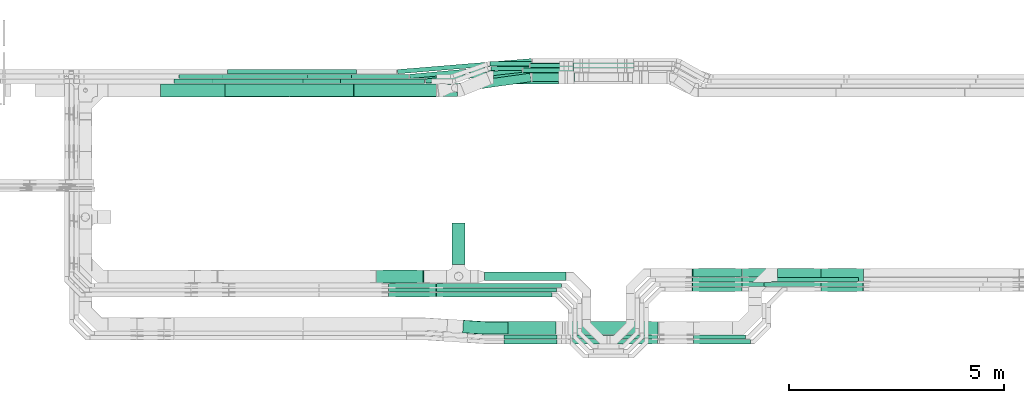
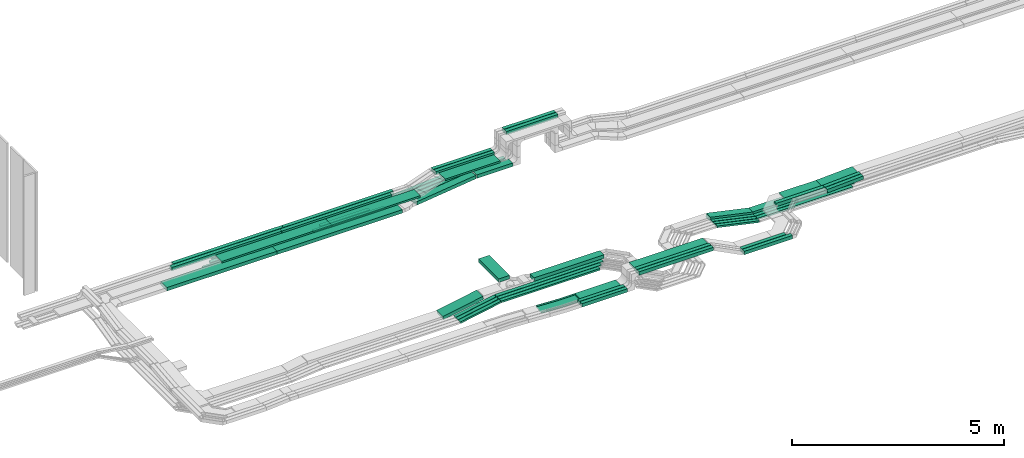
# One storey, part 2 of 33: 54 flow segments, 1 flow fitting.
"""IFC2X3 building model written with IfcOpenShell, lengths in millimetres."""

from ifc_helpers import new_model, entity, si_unit, converted_unit, derived_unit, direction, frame, frame_2d, origin, origin_2d_with_axis, place, context, subcontext, project, spatial, rectangle, extrude, faceted_brep, source, transform, mapped, material, type_object, type_shapes, element, save


model = new_model("IFC2X3")

# Units and contexts
model_context = context("Model", 3, precision=0.01, world=origin(), true_north=direction((6.12303176911189e-17, 1.0)))
body_context = subcontext(model_context, "Body", "Model", "MODEL_VIEW")
ifc_project = project(units=[si_unit("LENGTHUNIT", "METRE", prefix="MILLI"), si_unit("AREAUNIT", "SQUARE_METRE"), si_unit("VOLUMEUNIT", "CUBIC_METRE"), converted_unit("PLANEANGLEUNIT", "DEGREE", entity("IfcRatioMeasure", 0.0174532925199433), si_unit("PLANEANGLEUNIT", "RADIAN"), dimensions=[0, 0, 0, 0, 0, 0, 0]), si_unit("MASSUNIT", "GRAM", prefix="KILO"), derived_unit("MASSDENSITYUNIT", [(si_unit("MASSUNIT", "GRAM", prefix="KILO"), 1), (si_unit("LENGTHUNIT", "METRE"), -3)]), derived_unit("MOMENTOFINERTIAUNIT", [(si_unit("LENGTHUNIT", "METRE"), 4)]), si_unit("TIMEUNIT", "SECOND"), si_unit("FREQUENCYUNIT", "HERTZ"), si_unit("THERMODYNAMICTEMPERATUREUNIT", "DEGREE_CELSIUS"), derived_unit("THERMALTRANSMITTANCEUNIT", [(si_unit("MASSUNIT", "GRAM", prefix="KILO"), 1), (si_unit("THERMODYNAMICTEMPERATUREUNIT", "KELVIN"), -1), (si_unit("TIMEUNIT", "SECOND"), -3)]), derived_unit("VOLUMETRICFLOWRATEUNIT", [(si_unit("LENGTHUNIT", "METRE"), 3), (si_unit("TIMEUNIT", "SECOND"), -1)]), derived_unit("MASSFLOWRATEUNIT", [(si_unit("MASSUNIT", "GRAM", prefix="KILO"), 1), (si_unit("TIMEUNIT", "SECOND"), -1)]), derived_unit("ROTATIONALFREQUENCYUNIT", [(si_unit("TIMEUNIT", "SECOND"), -1)]), si_unit("ELECTRICCURRENTUNIT", "AMPERE"), si_unit("ELECTRICVOLTAGEUNIT", "VOLT"), si_unit("POWERUNIT", "WATT"), si_unit("FORCEUNIT", "NEWTON", prefix="KILO"), si_unit("ILLUMINANCEUNIT", "LUX"), si_unit("LUMINOUSFLUXUNIT", "LUMEN"), si_unit("LUMINOUSINTENSITYUNIT", "CANDELA"), derived_unit("USERDEFINED", [(si_unit("MASSUNIT", "GRAM", prefix="KILO"), -1), (si_unit("LENGTHUNIT", "METRE"), -2), (si_unit("TIMEUNIT", "SECOND"), 3), (si_unit("LUMINOUSFLUXUNIT", "LUMEN"), 1)]), derived_unit("LINEARVELOCITYUNIT", [(si_unit("LENGTHUNIT", "METRE"), 1), (si_unit("TIMEUNIT", "SECOND"), -1)]), si_unit("PRESSUREUNIT", "PASCAL"), derived_unit("USERDEFINED", [(si_unit("LENGTHUNIT", "METRE"), -2), (si_unit("MASSUNIT", "GRAM", prefix="KILO"), 1), (si_unit("TIMEUNIT", "SECOND"), -2)]), derived_unit("LINEARFORCEUNIT", [(si_unit("MASSUNIT", "GRAM", prefix="KILO"), 1), (si_unit("LENGTHUNIT", "METRE"), 1), (si_unit("TIMEUNIT", "SECOND"), -2), (si_unit("LENGTHUNIT", "METRE"), -1)]), derived_unit("PLANARFORCEUNIT", [(si_unit("MASSUNIT", "GRAM", prefix="KILO"), 1), (si_unit("LENGTHUNIT", "METRE"), 1), (si_unit("TIMEUNIT", "SECOND"), -2), (si_unit("LENGTHUNIT", "METRE"), -2)])], contexts=[model_context])

# Site, building, storey
site_placement = place(None, frame((0.0, -0.00077364408347762, 0.0)))
site = spatial("IfcSite", under=ifc_project, at=site_placement, CompositionType="ELEMENT")
building_placement = place(site_placement, origin())
building = spatial("IfcBuilding", under=site, at=building_placement, CompositionType="ELEMENT")
storey_placement = place(building_placement, frame((0.0, 0.0, 8100.0)))
storey = spatial("IfcBuildingStorey", under=building, at=storey_placement, CompositionType="ELEMENT", Elevation=8100.0)

# Flow segments
cable_carrier_segment_type = type_object("IfcCableCarrierSegmentType", PredefinedType="CABLETRAYSEGMENT")
flow_segment_1_placement = place(storey_placement, frame((26941.0061453203, 10274.9985534668, 2800.0)))
element("IfcFlowSegment", 1, at=flow_segment_1_placement, inside=storey, type_object=cable_carrier_segment_type, context=body_context, shape_type="SweptSolid", body=[
    extrude(rectangle(XDim=962.025403932725, YDim=300.000000000001, at=frame_2d((-1.08002495835535e-12, 0.0), x_axis=(1.0, 0.0))), frame((150.0, 481.012701966363, 0.0), z_axis=(0.0, 0.0, 1.0), x_axis=(0.0, 1.0, 0.0)), (0.0, 0.0, 1.0), 99.9999999999968),
])
flow_segment_2_placement = place(storey_placement, frame((23148.437324407, 14174.4992263561, 2565.0)))
element("IfcFlowSegment", 2, at=flow_segment_2_placement, inside=storey, type_object=cable_carrier_segment_type, context=body_context, shape_type="SweptSolid", body=[
    extrude(rectangle(XDim=3423.65642864429, YDim=300.000000000001, at=frame_2d((-2.1600499167107e-12, -1.08002495835535e-12), x_axis=(1.0, 0.0))), frame((1711.82821432215, 150.0, 0.0), z_axis=(0.0, 0.0, 1.0), x_axis=(-1.0, 0.0, 0.0)), (0.0, 0.0, 1.0), 99.9999999999989),
])
flow_segment_3_placement = place(storey_placement, frame((28591.6886277084, 14750.0572451365, 2565.34290576127)))
element("IfcFlowSegment", 3, at=flow_segment_3_placement, inside=storey, type_object=cable_carrier_segment_type, context=body_context, shape_type="SweptSolid", body=[
    extrude(rectangle(XDim=1171.51047122399, YDim=99.9999999999989, at=origin_2d_with_axis()), frame((585.755235611997, 50.0, 0.0), z_axis=(0.0, 0.0, 1.0), x_axis=(-1.0, 0.0, 0.0)), (0.0, 0.0, 1.0), 50.0000000000016),
])
flow_segment_4_placement = place(storey_placement, frame((28756.9717562962, 14860.0572451365, 2570.0)))
element("IfcFlowSegment", 4, at=flow_segment_4_placement, inside=storey, type_object=cable_carrier_segment_type, context=body_context, shape_type="SweptSolid", body=[
    extrude(rectangle(XDim=1006.22734263624, YDim=99.9999999999989, at=frame_2d((2.1600499167107e-12, 0.0), x_axis=(1.0, 0.0))), frame((503.11367131812, 50.0, 0.0), z_axis=(0.0, 0.0, 1.0), x_axis=(-1.0, 0.0, 0.0)), (0.0, 0.0, 1.0), 50.0000000000016),
])
flow_segment_5_placement = place(storey_placement, frame((27693.0061453203, 9894.99855346675, 2800.0)))
element("IfcFlowSegment", 5, at=flow_segment_5_placement, inside=storey, type_object=cable_carrier_segment_type, context=body_context, shape_type="SweptSolid", body=[
    extrude(rectangle(XDim=1902.46225527867, YDim=199.999999999998, at=frame_2d((-4.37694325228222e-12, 1.08002495835535e-12), x_axis=(1.0, 0.0))), frame((951.231127639338, 100.0, 0.0)), (0.0, 0.0, 1.0), 100.000000000001),
])
flow_segment_6_placement = place(storey_placement, frame((29758.1990989324, 14900.0572451365, 3324.99867972438)))
element("IfcFlowSegment", 6, at=flow_segment_6_placement, inside=storey, type_object=cable_carrier_segment_type, context=body_context, shape_type="SweptSolid", body=[
    extrude(rectangle(XDim=1413.21398337131, YDim=99.9999999999989, at=frame_2d((-2.1600499167107e-12, 0.0), x_axis=(1.0, 0.0))), frame((706.606991685651, 50.0, 0.0)), (0.0, 0.0, 1.0), 99.9999999999989),
])
flow_segment_7_placement = place(storey_placement, frame((29758.1990989324, 14790.0572451365, 3324.99867972438)))
element("IfcFlowSegment", 7, at=flow_segment_7_placement, inside=storey, type_object=cable_carrier_segment_type, context=body_context, shape_type="SweptSolid", body=[
    extrude(rectangle(XDim=1413.2139833713, YDim=99.9999999999989, at=origin_2d_with_axis()), frame((706.606991685651, 50.0, 0.0)), (0.0, 0.0, 1.0), 99.9999999999989),
])
flow_segment_8_placement = place(storey_placement, frame((27909.7567007501, 14480.0572451366, 2840.01712441882)))
element("IfcFlowSegment", 8, at=flow_segment_8_placement, inside=storey, type_object=cable_carrier_segment_type, context=body_context, shape_type="SweptSolid", body=[
    extrude(rectangle(XDim=1503.44239818237, YDim=300.000000000001, at=origin_2d_with_axis()), frame((751.721199091186, 150.0, 0.0), z_axis=(0.0, 0.0, 1.0), x_axis=(-1.0, 0.0, 0.0)), (0.0, 0.0, 1.0), 50.0000000000016),
])
flow_segment_9_placement = place(storey_placement, frame((27841.258991739, 14790.0572451365, 2840.0)))
element("IfcFlowSegment", 9, at=flow_segment_9_placement, inside=storey, type_object=cable_carrier_segment_type, context=body_context, shape_type="SweptSolid", body=[
    extrude(rectangle(XDim=1596.94010719343, YDim=99.9999999999989, at=frame_2d((-2.1600499167107e-12, 0.0), x_axis=(1.0, 0.0))), frame((798.470053596716, 50.0, 0.0), z_axis=(0.0, 0.0, 1.0), x_axis=(-1.0, 0.0, 0.0)), (0.0, 0.0, 1.0), 99.9999999999989),
])
flow_segment_10_placement = place(storey_placement, frame((27825.5058887975, 14900.0572451365, 2840.0)))
element("IfcFlowSegment", 10, at=flow_segment_10_placement, inside=storey, type_object=cable_carrier_segment_type, context=body_context, shape_type="SweptSolid", body=[
    extrude(rectangle(XDim=1612.69321013494, YDim=99.9999999999989, at=frame_2d((2.1600499167107e-12, -2.16715534406831e-12), x_axis=(1.0, 0.0))), frame((806.346605067471, 50.0, 0.0), z_axis=(0.0, 0.0, 1.0), x_axis=(-1.0, 0.0, 0.0)), (0.0, 0.0, 1.0), 99.9999999999989),
])
flow_segment_11_placement = place(storey_placement, frame((28805.1753458545, 14532.2782357463, 2565.0)))
element("IfcFlowSegment", 11, at=flow_segment_11_placement, inside=storey, type_object=cable_carrier_segment_type, context=body_context, shape_type="SweptSolid", body=[
    extrude(rectangle(XDim=983.02375307789, YDim=199.999999999998, at=frame_2d((0.0, 1.08002495835535e-12), x_axis=(1.0, 0.0))), frame((491.511876538945, 100.0, 0.0), z_axis=(0.0, 0.0, 1.0), x_axis=(-1.0, 0.0, 0.0)), (0.0, 0.0, 1.0), 99.9999999999989),
])
flow_segment_12_placement = place(storey_placement, frame((26317.4081518589, 14493.9896855874, 2565.34290576127)))
element("IfcFlowSegment", 12, at=flow_segment_12_placement, inside=storey, type_object=cable_carrier_segment_type, context=body_context, shape_type="SweptSolid", body=[
    extrude(rectangle(XDim=2258.501959598, YDim=99.9999999999987, at=frame_2d((2.27373675443232e-12, 8.20676859802916e-13), x_axis=(1.0, 0.0))), frame((1127.67558113492, 177.178054854003, 0.0), z_axis=(0.0, 0.0, 1.0), x_axis=(-0.993605819509294, -0.112904718401246, 0.0)), (0.0, 0.0, 1.0), 50.0000000000016),
])
flow_segment_13_placement = place(storey_placement, frame((25948.9674028795, 14603.4200619656, 2570.0)))
element("IfcFlowSegment", 13, at=flow_segment_13_placement, inside=storey, type_object=cable_carrier_segment_type, context=body_context, shape_type="SweptSolid", body=[
    extrude(rectangle(XDim=2794.85823056188, YDim=100.000000000001, at=frame_2d((-2.27373675443232e-12, -8.88178419700125e-13), x_axis=(1.0, 0.0))), frame((1396.13678772422, 177.747678475758, 0.0), z_axis=(0.0, 0.0, 1.0), x_axis=(-0.995798961229457, -0.0915665267132783, 0.0)), (0.0, 0.0, 1.0), 50.0000000000016),
])
flow_segment_14_placement = place(storey_placement, frame((25661.8401583002, 14713.1975785163, 2570.0)))
element("IfcFlowSegment", 14, at=flow_segment_14_placement, inside=storey, type_object=cable_carrier_segment_type, context=body_context, shape_type="SweptSolid", body=[
    extrude(rectangle(XDim=3133.42412206089, YDim=100.000000000001, at=frame_2d((2.38742359215394e-12, 9.05941988094128e-13), x_axis=(1.0, 0.0))), frame((1565.55261180843, 177.970161925087, 0.0), z_axis=(0.0, 0.0, 1.0), x_axis=(-0.996649779456723, -0.0817876342050842, 0.0)), (0.0, 0.0, 1.0), 50.0000000000016),
])
flow_segment_15_placement = place(storey_placement, frame((26998.0016521339, 14284.1233659658, 2564.99985076257)))
element("IfcFlowSegment", 15, at=flow_segment_15_placement, inside=storey, type_object=cable_carrier_segment_type, context=body_context, shape_type="SweptSolid", body=[
    extrude(rectangle(XDim=1773.75184296437, YDim=200.000000000002, at=frame_2d((2.50111042987555e-12, 1.83320025826106e-12), x_axis=(1.0, 0.0))), frame((892.166363008045, 222.308987595649, 6.35650108506525e-05), z_axis=(-7.09771272186529e-08, -9.962867704376e-09, 1.0), x_axis=(0.990291738549351, 0.139004577481819, 7.16729469263524e-08)), (0.0, 0.0, 1.0), 99.9999999999991),
])
flow_segment_16_placement = place(storey_placement, frame((29699.4603210585, 8532.45182054437, 3165.01712441883)))
element("IfcFlowSegment", 16, at=flow_segment_16_placement, inside=storey, type_object=cable_carrier_segment_type, context=body_context, shape_type="SweptSolid", body=[
    extrude(rectangle(XDim=2026.05061924203, YDim=99.9999999999989, at=frame_2d((0.0, -5.40012479177676e-13), x_axis=(1.0, 0.0))), frame((1013.02530962102, 50.0, 0.0)), (0.0, 0.0, 1.0), 99.9999999999989),
])
flow_segment_17_placement = place(storey_placement, frame((29699.4603210585, 8422.4518205444, 3164.29820786533)))
element("IfcFlowSegment", 17, at=flow_segment_17_placement, inside=storey, type_object=cable_carrier_segment_type, context=body_context, shape_type="SweptSolid", body=[
    extrude(rectangle(XDim=2026.05032171429, YDim=99.9999999999989, at=frame_2d((-2.21689333557151e-12, -5.40012479177676e-13), x_axis=(1.0, 0.0))), frame((1013.02516085715, 50.0, 0.0)), (0.0, 0.0, 1.0), 99.9999999999989),
])
flow_segment_18_placement = place(storey_placement, frame((26574.4374224017, 9734.99855346668, 2800.0)))
element("IfcFlowSegment", 18, at=flow_segment_18_placement, inside=storey, type_object=cable_carrier_segment_type, context=body_context, shape_type="SweptSolid", body=[
    extrude(rectangle(XDim=2911.03097819719, YDim=99.9999999999989, at=frame_2d((-4.32009983342141e-12, 0.0), x_axis=(1.0, 0.0))), frame((1455.5154890986, 50.0, 0.0)), (0.0, 0.0, 1.0), 50.0000000000016),
])
flow_segment_19_placement = place(storey_placement, frame((26574.2635118307, 9625.47519661137, 2800.0)))
element("IfcFlowSegment", 19, at=flow_segment_19_placement, inside=storey, type_object=cable_carrier_segment_type, context=body_context, shape_type="SweptSolid", body=[
    extrude(rectangle(XDim=2801.68153191295, YDim=99.9999999999989, at=frame_2d((2.1600499167107e-12, -5.40012479177676e-13), x_axis=(1.0, 0.0))), frame((1400.84076595647, 50.0, 0.0)), (0.0, 0.0, 1.0), 50.0000000000016),
])
flow_segment_20_placement = place(storey_placement, frame((29724.4603210585, 8642.0466811094, 3165.01711365164)))
element("IfcFlowSegment", 20, at=flow_segment_20_placement, inside=storey, type_object=cable_carrier_segment_type, context=body_context, shape_type="SweptSolid", body=[
    extrude(rectangle(XDim=2007.04579485695, YDim=300.000000000001, at=frame_2d((0.0, 5.40012479177676e-13), x_axis=(1.0, 0.0))), frame((1003.52289742848, 150.0, 0.0)), (0.0, 0.0, 1.0), 50.0000000000016),
])
flow_segment_21_placement = place(storey_placement, frame((21649.8223642021, 14182.2782357464, 2840.01712441882)))
element("IfcFlowSegment", 21, at=flow_segment_21_placement, inside=storey, type_object=cable_carrier_segment_type, context=body_context, shape_type="SweptSolid", body=[
    extrude(rectangle(XDim=2997.46000001016, YDim=300.000000000001, at=frame_2d((2.1600499167107e-12, 0.0), x_axis=(1.0, 0.0))), frame((1498.73000000508, 150.0, 0.0)), (0.0, 0.0, 1.0), 50.0000000000016),
])
flow_segment_22_placement = place(storey_placement, frame((24649.8223642021, 14182.2782357464, 2840.01712441882)))
element("IfcFlowSegment", 22, at=flow_segment_22_placement, inside=storey, type_object=cable_carrier_segment_type, context=body_context, shape_type="SweptSolid", body=[
    extrude(rectangle(XDim=2417.52833008933, YDim=300.000000000001, at=frame_2d((-2.1600499167107e-12, 0.0), x_axis=(1.0, 0.0))), frame((1208.76416504467, 150.0, 0.0)), (0.0, 0.0, 1.0), 50.0000000000016),
])
flow_segment_23_placement = place(storey_placement, frame((21709.6133048514, 14712.2782357463, 2570.0)))
element("IfcFlowSegment", 23, at=flow_segment_23_placement, inside=storey, type_object=cable_carrier_segment_type, context=body_context, shape_type="SweptSolid", body=[
    extrude(rectangle(XDim=2997.46000001016, YDim=99.9999999999989, at=frame_2d((2.1600499167107e-12, 2.16715534406831e-12), x_axis=(1.0, 0.0))), frame((1498.73000000508, 50.0, 0.0)), (0.0, 0.0, 1.0), 50.0000000000016),
])
flow_segment_24_placement = place(storey_placement, frame((21594.0456084693, 14602.2782357463, 2570.0)))
element("IfcFlowSegment", 24, at=flow_segment_24_placement, inside=storey, type_object=cable_carrier_segment_type, context=body_context, shape_type="SweptSolid", body=[
    extrude(rectangle(XDim=2997.46000001016, YDim=99.9999999999989, at=origin_2d_with_axis()), frame((1498.73000000508, 50.0, 0.0)), (0.0, 0.0, 1.0), 50.0000000000016),
])
flow_segment_25_placement = place(storey_placement, frame((24594.0456084693, 14602.2782357463, 2570.0)))
element("IfcFlowSegment", 25, at=flow_segment_25_placement, inside=storey, type_object=cable_carrier_segment_type, context=body_context, shape_type="SweptSolid", body=[
    extrude(rectangle(XDim=1339.19101644203, YDim=99.9999999999989, at=origin_2d_with_axis()), frame((669.595508221013, 50.0, 0.0)), (0.0, 0.0, 1.0), 50.0000000000016),
])
flow_segment_26_placement = place(storey_placement, frame((33696.8429937295, 9754.99855346681, 2546.31908538347)))
element("IfcFlowSegment", 26, at=flow_segment_26_placement, inside=storey, type_object=cable_carrier_segment_type, context=body_context, shape_type="SweptSolid", body=[
    extrude(rectangle(XDim=2604.87236655356, YDim=99.9999999999989, at=frame_2d((2.27373675443232e-12, 0.0), x_axis=(1.0, 0.0))), frame((1302.43618327678, 50.0, 0.0), z_axis=(0.0, 0.0, 1.0), x_axis=(-1.0, 0.0, 0.0)), (0.0, 0.0, 1.0), 50.0000000000016),
])
flow_segment_27_placement = place(storey_placement, frame((20464.099792896, 14492.2782357464, 2840.0)))
element("IfcFlowSegment", 27, at=flow_segment_27_placement, inside=storey, type_object=cable_carrier_segment_type, context=body_context, shape_type="SweptSolid", body=[
    extrude(rectangle(XDim=2997.46000001016, YDim=99.9999999999989, at=origin_2d_with_axis()), frame((1498.73000000508, 50.0, 0.0)), (0.0, 0.0, 1.0), 99.9999999999989),
])
flow_segment_28_placement = place(storey_placement, frame((23464.099792896, 14492.2782357463, 2840.0)))
element("IfcFlowSegment", 28, at=flow_segment_28_placement, inside=storey, type_object=cable_carrier_segment_type, context=body_context, shape_type="SweptSolid", body=[
    extrude(rectangle(XDim=2997.46000001016, YDim=99.9999999999989, at=frame_2d((2.1600499167107e-12, 0.0), x_axis=(1.0, 0.0))), frame((1498.73000000508, 50.0, 0.0)), (0.0, 0.0, 1.0), 99.9999999999989),
])
flow_segment_29_placement = place(storey_placement, frame((20148.437324407, 14174.4992263561, 2565.0)))
element("IfcFlowSegment", 29, at=flow_segment_29_placement, inside=storey, type_object=cable_carrier_segment_type, context=body_context, shape_type="SweptSolid", body=[
    extrude(rectangle(XDim=2997.46000001016, YDim=300.000000000001, at=origin_2d_with_axis()), frame((1498.73000000508, 150.0, 0.0), z_axis=(0.0, 0.0, 1.0), x_axis=(-1.0, 0.0, 0.0)), (0.0, 0.0, 1.0), 99.9999999999989),
])
flow_segment_30_placement = place(storey_placement, frame((33699.5150941082, 9974.99855346669, 2547.39498136105)))
element("IfcFlowSegment", 30, at=flow_segment_30_placement, inside=storey, type_object=cable_carrier_segment_type, context=body_context, shape_type="SweptSolid", body=[
    extrude(rectangle(XDim=2791.19312349986, YDim=200.000000000002, at=frame_2d((2.1600499167107e-12, 1.08713038571295e-12), x_axis=(1.0, 0.0))), frame((1395.59656174994, 100.0, 0.0), z_axis=(0.0, 0.0, 1.0), x_axis=(-1.0, 0.0, 0.0)), (0.0, 0.0, 1.0), 99.9999999999989),
])
flow_segment_31_placement = place(storey_placement, frame((21344.7823642123, 14492.2782357463, 2565.34290576127)))
element("IfcFlowSegment", 31, at=flow_segment_31_placement, inside=storey, type_object=cable_carrier_segment_type, context=body_context, shape_type="SweptSolid", body=[
    extrude(rectangle(XDim=2997.46000001016, YDim=99.9999999999989, at=frame_2d((-2.1600499167107e-12, 0.0), x_axis=(1.0, 0.0))), frame((1498.73000000508, 50.0, 0.0)), (0.0, 0.0, 1.0), 50.0000000000016),
])
flow_segment_32_placement = place(storey_placement, frame((24344.7823642123, 14492.2782357463, 2565.34290576127)))
element("IfcFlowSegment", 32, at=flow_segment_32_placement, inside=storey, type_object=cable_carrier_segment_type, context=body_context, shape_type="SweptSolid", body=[
    extrude(rectangle(XDim=1953.69647406687, YDim=99.9999999999989, at=frame_2d((2.1600499167107e-12, 0.0), x_axis=(1.0, 0.0))), frame((976.84823703343, 50.0, 0.0)), (0.0, 0.0, 1.0), 50.0000000000016),
])
flow_segment_33_placement = place(storey_placement, frame((33696.8597770326, 9864.99855346681, 2544.92549664432)))
element("IfcFlowSegment", 33, at=flow_segment_33_placement, inside=storey, type_object=cable_carrier_segment_type, context=body_context, shape_type="SweptSolid", body=[
    extrude(rectangle(XDim=2714.85558325048, YDim=99.9999999999989, at=frame_2d((2.1600499167107e-12, 0.0), x_axis=(1.0, 0.0))), frame((1357.42779162524, 50.0, 0.0), z_axis=(0.0, 0.0, 1.0), x_axis=(-1.0, 0.0, 0.0)), (0.0, 0.0, 1.0), 50.0000000000016),
])
for number, where in (
    (34, (20574.099792896, 14602.2782357463, 2840.0)),
    (35, (23574.099792896, 14602.2782357463, 2840.0)),
):
    element("IfcFlowSegment", number, at=place(storey_placement, frame(where)), inside=storey, type_object=cable_carrier_segment_type, context=body_context, shape_type="SweptSolid", body=[
        extrude(rectangle(XDim=2997.46000001016, YDim=99.9999999999989, at=frame_2d((2.1600499167107e-12, 0.0), x_axis=(1.0, 0.0))), frame((1498.73000000508, 50.0, 0.0)), (0.0, 0.0, 1.0), 99.9999999999989),
    ])
flow_segment_34_placement = place(storey_placement, frame((28145.4603210579, 8532.45182054432, 2789.66918252178)))
element("IfcFlowSegment", 36, at=flow_segment_34_placement, inside=storey, type_object=cable_carrier_segment_type, context=body_context, shape_type="SweptSolid", body=[
    extrude(rectangle(XDim=1234.00000000056, YDim=100.000000000001, at=frame_2d((-2.1600499167107e-12, 5.43565192856477e-13), x_axis=(1.0, 0.0))), frame((617.0, 50.0, 0.0), z_axis=(0.0, 0.0, 1.0), x_axis=(-1.0, 0.0, 0.0)), (0.0, 0.0, 1.0), 99.9999999999989),
])
flow_segment_35_placement = place(storey_placement, frame((28245.4603210302, 8642.04668110937, 2790.01530223368)))
element("IfcFlowSegment", 37, at=flow_segment_35_placement, inside=storey, type_object=cable_carrier_segment_type, context=body_context, shape_type="SweptSolid", body=[
    extrude(rectangle(XDim=1109.00000002828, YDim=299.999999999999, at=frame_2d((2.1600499167107e-12, 0.0), x_axis=(1.0, 0.0))), frame((554.500000014142, 150.0, 0.0), z_axis=(0.0, 0.0, 1.0), x_axis=(-1.0, 0.0, 0.0)), (0.0, 0.0, 1.0), 50.0000000000016),
])
flow_segment_36_placement = place(storey_placement, frame((28145.4603210581, 8422.45182054439, 2789.31932519731)))
element("IfcFlowSegment", 38, at=flow_segment_36_placement, inside=storey, type_object=cable_carrier_segment_type, context=body_context, shape_type="SweptSolid", body=[
    extrude(rectangle(XDim=1234.00000000042, YDim=100.000000000001, at=frame_2d((0.0, 5.43565192856477e-13), x_axis=(1.0, 0.0))), frame((617.0, 50.0, 0.0), z_axis=(0.0, 0.0, 1.0), x_axis=(-1.0, 0.0, 0.0)), (0.0, 0.0, 1.0), 100.000000000001),
])
flow_segment_37_placement = place(storey_placement, frame((25457.5422844061, 9515.47519661141, 2591.61010487083)))
element("IfcFlowSegment", 39, at=flow_segment_37_placement, inside=storey, type_object=cable_carrier_segment_type, context=body_context, shape_type="SweptSolid", body=[
    extrude(rectangle(XDim=49.9999999999993, YDim=99.9999999999989, at=origin_2d_with_axis()), frame((4.62605322155065, 50.0, 24.5682647248715), z_axis=(0.982730588994872, 0.0, 0.185042128862028), x_axis=(-0.185042128862028, 0.0, 0.982730588994872)), (0.0, 0.0, 1.0), 1124.80210120938),
])
flow_segment_38_placement = place(storey_placement, frame((25457.5405769993, 9625.47519661143, 2591.55041955147)))
element("IfcFlowSegment", 40, at=flow_segment_38_placement, inside=storey, type_object=cable_carrier_segment_type, context=body_context, shape_type="SweptSolid", body=[
    extrude(rectangle(XDim=50.0000000000024, YDim=100.000000000001, at=frame_2d((-4.01456645704457e-13, 0.0), x_axis=(1.0, 0.0))), frame((4.62990844895072, 50.0, 24.5675384960398), z_axis=(0.982701539841543, 0.0, 0.18519633795802), x_axis=(-0.18519633795802, 0.0, 0.982701539841543)), (0.0, 0.0, 1.0), 1124.18632336721),
])
flow_segment_39_placement = place(storey_placement, frame((25457.5288054374, 9734.99855346673, 2590.28651598417)))
element("IfcFlowSegment", 41, at=flow_segment_39_placement, inside=storey, type_object=cable_carrier_segment_type, context=body_context, shape_type="SweptSolid", body=[
    extrude(rectangle(XDim=50.0000000000009, YDim=99.9999999999989, at=origin_2d_with_axis()), frame((4.65648018057559, 50.0, 24.5625160015794), z_axis=(0.982500640063244, 0.0, 0.186259207222934), x_axis=(-0.186259207222934, 0.0, 0.982500640063244)), (0.0, 0.0, 1.0), 1124.54697135174),
])
flow_segment_40_placement = place(storey_placement, frame((25175.2531838889, 9844.99855346683, 2596.96040688293)))
element("IfcFlowSegment", 42, at=flow_segment_40_placement, inside=storey, type_object=cable_carrier_segment_type, context=body_context, shape_type="SweptSolid", body=[
    extrude(rectangle(XDim=99.999999999999, YDim=300.000000000001, at=origin_2d_with_axis()), frame((9.159880915031, 150.0, 49.1538053625812), z_axis=(0.983076107251635, 0.0, 0.183197618300492), x_axis=(-0.183197618300492, 0.0, 0.983076107251635)), (0.0, 0.0, 1.0), 1106.93960876275),
])
flow_segment_41_placement = place(storey_placement, frame((26574.8947213778, 9515.47519661137, 2800.0)))
element("IfcFlowSegment", 43, at=flow_segment_41_placement, inside=storey, type_object=cable_carrier_segment_type, context=body_context, shape_type="SweptSolid", body=[
    extrude(rectangle(XDim=2691.05032236578, YDim=99.9999999999989, at=frame_2d((-2.1600499167107e-12, 0.0), x_axis=(1.0, 0.0))), frame((1345.52516118289, 50.0, 0.0)), (0.0, 0.0, 1.0), 50.0000000000016),
])
flow_segment_42_placement = place(storey_placement, frame((34520.3227446955, 9874.99855346677, 2750.01711339306)))
element("IfcFlowSegment", 44, at=flow_segment_42_placement, inside=storey, type_object=cable_carrier_segment_type, context=body_context, shape_type="SweptSolid", body=[
    extrude(rectangle(XDim=1011.86137418036, YDim=300.000000000001, at=frame_2d((-2.1600499167107e-12, 1.08002495835535e-12), x_axis=(1.0, 0.0))), frame((505.930687090181, 150.0, 0.0)), (0.0, 0.0, 1.0), 50.0000000000016),
])
flow_segment_43_placement = place(storey_placement, frame((34203.9176052606, 9754.99855346677, 2750.01096864734)))
element("IfcFlowSegment", 45, at=flow_segment_43_placement, inside=storey, type_object=cable_carrier_segment_type, context=body_context, shape_type="SweptSolid", body=[
    extrude(rectangle(XDim=1327.63419776575, YDim=99.9999999999989, at=frame_2d((-2.1600499167107e-12, 0.0), x_axis=(1.0, 0.0))), frame((663.817098882877, 50.0, 0.0)), (0.0, 0.0, 1.0), 99.9999999999989),
])
flow_segment_44_placement = place(storey_placement, frame((32568.9549458938, 8532.45182054437, 2750.01096864735)))
element("IfcFlowSegment", 46, at=flow_segment_44_placement, inside=storey, type_object=cable_carrier_segment_type, context=body_context, shape_type="SweptSolid", body=[
    extrude(rectangle(XDim=1208.96265936677, YDim=99.9999999999989, at=frame_2d((-2.21689333557151e-12, 0.0), x_axis=(1.0, 0.0))), frame((604.48132968339, 50.0, 0.0)), (0.0, 0.0, 1.0), 99.9999999999989),
])
flow_segment_45_placement = place(storey_placement, frame((32568.9552434214, 8422.45182054438, 2749.28135320931)))
element("IfcFlowSegment", 47, at=flow_segment_45_placement, inside=storey, type_object=cable_carrier_segment_type, context=body_context, shape_type="SweptSolid", body=[
    extrude(rectangle(XDim=1318.96236183914, YDim=99.9999999999989, at=frame_2d((-2.1600499167107e-12, 5.40012479177676e-13), x_axis=(1.0, 0.0))), frame((659.481180919577, 50.0, 0.0)), (0.0, 0.0, 1.0), 99.9999999999989),
])
flow_segment_46_placement = place(storey_placement, frame((35533.752736123, 9644.99855346677, 2749.46488227597)))
element("IfcFlowSegment", 48, at=flow_segment_46_placement, inside=storey, type_object=cable_carrier_segment_type, context=body_context, shape_type="SweptSolid", body=[
    extrude(rectangle(XDim=99.999999999999, YDim=99.9999999999989, at=origin_2d_with_axis()), frame((2.52764641903952, 50.0, 49.9360691642851), z_axis=(0.998721383285712, 0.0, 0.050552928380791), x_axis=(-0.050552928380791, 0.0, 0.998721383285712)), (0.0, 0.0, 1.0), 984.330782250709),
])
flow_segment_47_placement = place(storey_placement, frame((35533.7527361231, 9754.99855346677, 2750.19449771401)))
element("IfcFlowSegment", 49, at=flow_segment_47_placement, inside=storey, type_object=cable_carrier_segment_type, context=body_context, shape_type="SweptSolid", body=[
    extrude(rectangle(XDim=99.999999999999, YDim=99.9999999999989, at=origin_2d_with_axis()), frame((2.52764641903952, 50.0, 49.9360691642851), z_axis=(0.998721383285712, 0.0, 0.050552928380791), x_axis=(-0.050552928380791, 0.0, 0.998721383285712)), (0.0, 0.0, 1.0), 984.330782250623),
])
flow_segment_48_placement = place(storey_placement, frame((35534.3850519727, 9874.99855346676, 2750.13671162401)))
element("IfcFlowSegment", 50, at=flow_segment_48_placement, inside=storey, type_object=cable_carrier_segment_type, context=body_context, shape_type="SweptSolid", body=[
    extrude(rectangle(XDim=50.0000000000017, YDim=300.000000000001, at=origin_2d_with_axis()), frame((1.26382320952409, 150.0, 24.9680345821436), z_axis=(0.998721383285712, 0.0, 0.0505529283807888), x_axis=(-0.0505529283807888, 0.0, 0.998721383285712)), (0.0, 0.0, 1.0), 985.595413949781),
])
flow_segment_49_placement = place(storey_placement, frame((32529.011756293, 9644.99855346694, 2548.08484511224)))
element("IfcFlowSegment", 51, at=flow_segment_49_placement, inside=storey, type_object=cable_carrier_segment_type, context=body_context, shape_type="SweptSolid", body=[
    extrude(rectangle(XDim=49.9999999999996, YDim=100.000000000001, at=origin_2d_with_axis()), frame((5.32417156613482, 50.0, 276.036911282604), z_axis=(0.977059422663216, 0.0, -0.212966862645394), x_axis=(0.212966862645394, 0.0, 0.977059422663216)), (0.0, 0.0, 1.0), 1181.45340824707),
])
flow_segment_50_placement = place(storey_placement, frame((32529.0089266438, 9754.99855346686, 2547.7740626078)))
element("IfcFlowSegment", 52, at=flow_segment_50_placement, inside=storey, type_object=cable_carrier_segment_type, context=body_context, shape_type="SweptSolid", body=[
    extrude(rectangle(XDim=50.000000000001, YDim=99.9999999999989, at=origin_2d_with_axis()), frame((5.33047009974847, 50.0, 276.345848325476), z_axis=(0.977004473697588, 0.0, -0.213218803989935), x_axis=(0.213218803989935, 0.0, 0.977004473697588)), (0.0, 0.0, 1.0), 1181.51275482673),
])
flow_segment_51_placement = place(storey_placement, frame((32528.9963693255, 9864.99855346684, 2546.39479887883)))
element("IfcFlowSegment", 53, at=flow_segment_51_placement, inside=storey, type_object=cable_carrier_segment_type, context=body_context, shape_type="SweptSolid", body=[
    extrude(rectangle(XDim=49.9999999999984, YDim=99.9999999999989, at=origin_2d_with_axis()), frame((5.35841113509382, 50.0, 277.716901566837), z_axis=(0.976759892794414, 0.0, -0.214336445403586), x_axis=(0.214336445403586, 0.0, 0.976759892794414)), (0.0, 0.0, 1.0), 1181.77710640849),
])
flow_segment_52_placement = place(storey_placement, frame((32526.3335605825, 9974.99855346669, 2549.9793160665)))
element("IfcFlowSegment", 54, at=flow_segment_52_placement, inside=storey, type_object=cable_carrier_segment_type, context=body_context, shape_type="SweptSolid", body=[
    extrude(rectangle(XDim=99.9999999999999, YDim=200.000000000002, at=origin_2d_with_axis()), frame((10.6177687578861, 100.0, 298.576723906112), z_axis=(0.977192506439557, 0.0, -0.212355375157721), x_axis=(0.212355375157721, 0.0, 0.977192506439557)), (0.0, 0.0, 1.0), 1175.93961725075),
])

# Flow fitting
ifc_material = material()
cable_carrier_fitting_type = type_object("IfcCableCarrierFittingType", Name="470_DKC_G5_Sheet horizontal bend:-", PredefinedType="NOTDEFINED", material=ifc_material)
shared_shape = source(origin(), body_context, "Body", "Brep", [
    faceted_brep([(-526.0, -150.0, -25.0), (-526.0, -150.0, 25.0), (-526.0, -145.0, 25.0), (-526.0, -145.0, -20.0), (-526.0, 145.0, -20.0), (-526.0, 145.0, 25.0), (-526.0, 150.0, 25.0), (-526.0, 150.0, -25.0), (4.75933073623803, -150.0, -25.0), (4.75933073623803, -150.0, 25.0), (534.451082788922, -116.353083782761, 25.0), (534.134113173234, -111.363140870991, 25.0), (4.60068637836366, -145.0, 25.0), (4.60068637836366, -145.0, -20.0), (534.134113173234, -111.363140870991, -20.0), (515.749875463334, 178.05354801171, -20.0), (-4.60068637835114, 145.0, -20.0), (-4.60068637835114, 145.0, 25.0), (515.749875463334, 178.05354801171, 25.0), (515.432905847646, 183.04349092348, 25.0), (-4.75933073622551, 150.0, 25.0), (-4.75933073622558, 150.0, -25.0), (515.432905847646, 183.043490923481, -25.0), (534.451082788922, -116.353083782761, -25.0)], [[[0, 1, 2, 3, 4, 5, 6, 7]], [[1, 0, 8, 9]], [[2, 1, 9, 10, 11, 12]], [[3, 2, 12, 13]], [[4, 3, 13, 14, 15, 16]], [[5, 4, 16, 17]], [[6, 5, 17, 18, 19, 20]], [[7, 6, 20, 21]], [[8, 0, 7, 21, 22, 23]], [[23, 22, 19, 18, 15, 14, 11, 10]], [[9, 8, 23, 10]], [[13, 12, 11, 14]], [[17, 16, 15, 18]], [[21, 20, 19, 22]]]),
])
type_shapes(cable_carrier_fitting_type, [shared_shape])
flow_fitting_placement = place(storey_placement, frame((27719.46032103, 8792.04668110938, 2815.01530223368), z_axis=(0.0, 0.0, 1.0), x_axis=(0.997988582354136, -0.0633939231376403, 0.0)))
element("IfcFlowFitting", 55, at=flow_fitting_placement, inside=storey, type_object=cable_carrier_fitting_type, material=ifc_material, Name="470_DKC_G5_Sheet horizontal bend:-", ObjectType="470_DKC_G5_Sheet horizontal bend:-", context=body_context, shape_type="MappedRepresentation", body=[
    mapped(shared_shape, transform((0.0, 0.0, 0.0), scale=1.0)),
])

save(model, "model.ifc")
